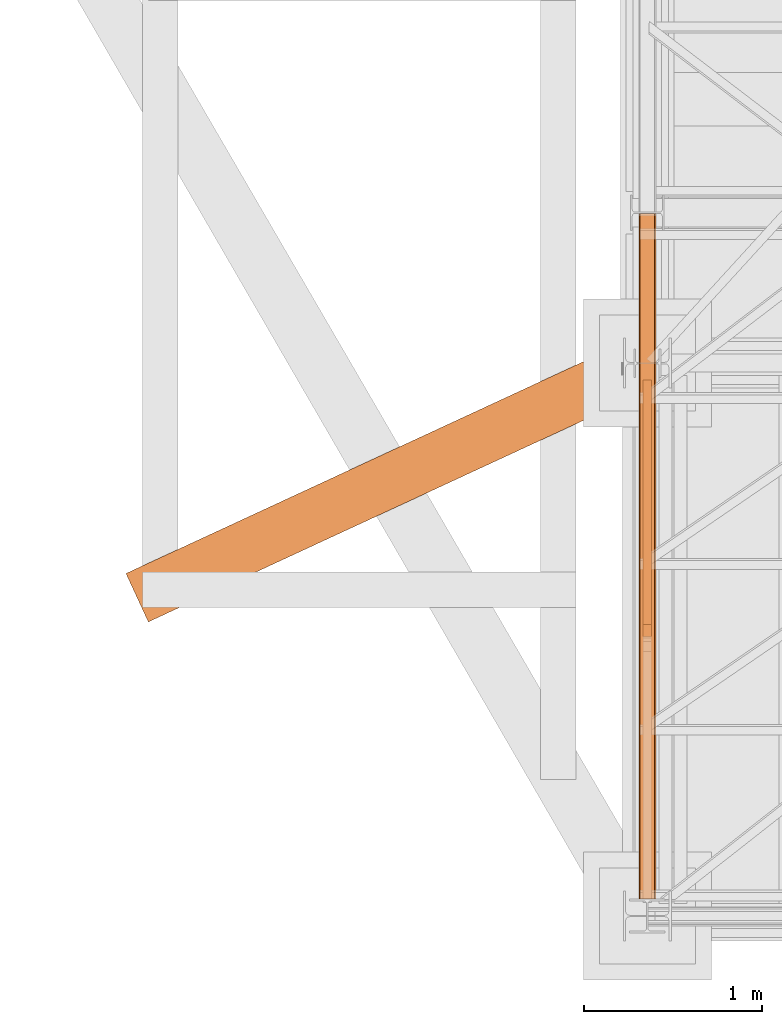
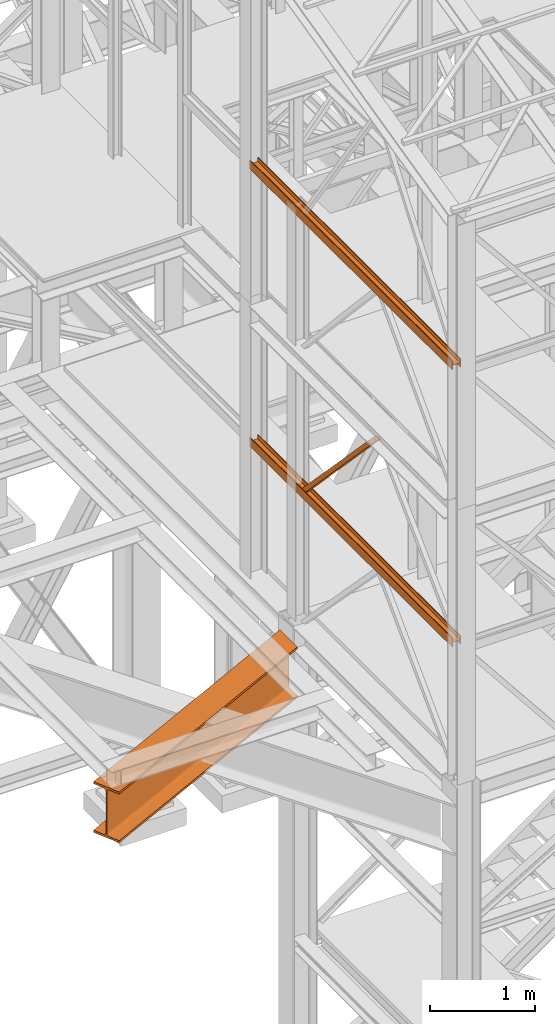
# One storey, part 11 of 208: 5 proxies.
"""IFC2X3 building model written with IfcOpenShell, lengths in millimetres."""

import ifcopenshell
import ifcopenshell.guid

model = None  # the IFC model being written
_history = None  # IfcOwnerHistory: only IFC2X3 demands one
_inside = {}  # id of a spatial element -> (the spatial element, [elements in it])
_under = {}  # id of a project, library or spatial element -> (it, [spatial elements below it])
_declared = {}  # id of a project -> (the project, [libraries it declares])
_typed = {}  # id of a type object -> (the type object, [elements of that type])
_made_of = {}  # id of a material, layer set ... -> (it, [elements and type objects made of it])


def new_model(schema):
    """Start an empty IFC model of exactly this schema.

    Asked for "IFC4X3", IfcOpenShell would pick the latest addendum, in which some entities
    have other attributes; the version numbers below select the first issue.
    IFC2X3 requires an IfcOwnerHistory on every rooted entity: one is made here for all.
    """
    global model, _history
    if schema == "IFC4X3":
        model = ifcopenshell.file(schema_version=(4, 3, 0, 0))
    else:
        model = ifcopenshell.file(schema=schema)
    _inside.clear()
    _under.clear()
    _declared.clear()
    _typed.clear()
    _made_of.clear()
    _history = None
    if model.schema == "IFC2X3":
        org = make("IfcOrganization", Name="unknown")
        user = make(
            "IfcPersonAndOrganization",
            ThePerson=make("IfcPerson", FamilyName="unknown"),
            TheOrganization=org,
        )
        app = make(
            "IfcApplication",
            ApplicationDeveloper=org,
            Version="unknown",
            ApplicationFullName="unknown",
            ApplicationIdentifier="unknown",
        )
        _history = make(
            "IfcOwnerHistory",
            OwningUser=user,
            OwningApplication=app,
            ChangeAction="ADDED",
            CreationDate=0,
        )
    return model


def make(cls, **values):
    """One entity of the class cls with the attributes given. An attribute that is None is left unset."""
    return model.create_entity(
        cls, **{name: value for name, value in values.items() if value is not None}
    )


def entity(cls, *values):
    """Any entity or typed value of the class cls, its attributes in the order of the schema. None: left unset."""
    e = model.create_entity(cls)
    for i, value in enumerate(values):
        if value is not None:
            e[i] = value
    return e


def rooted(cls, **values):
    """An entity with a GlobalId (a new one), such as an element, a storey or a relation."""
    return make(cls, GlobalId=ifcopenshell.guid.new(), OwnerHistory=_history, **values)


def si_unit(unit_type, name, prefix=None):
    """IfcSIUnit, for example si_unit("LENGTHUNIT", "METRE", prefix="MILLI")."""
    return make("IfcSIUnit", UnitType=unit_type, Prefix=prefix, Name=name)


def converted_unit(unit_type, name, factor, base, dimensions=None, offset=None):
    """IfcConversionBasedUnit, such as the inch: factor (a typed value) times the base unit."""
    return make(
        "IfcConversionBasedUnit"
        if offset is None
        else "IfcConversionBasedUnitWithOffset",
        ConversionOffset=offset,
        Dimensions=None
        if dimensions is None
        else entity("IfcDimensionalExponents", *dimensions),
        UnitType=unit_type,
        Name=name,
        ConversionFactor=make(
            "IfcMeasureWithUnit", ValueComponent=factor, UnitComponent=base
        ),
    )


def assignment(units):
    """IfcUnitAssignment: the units of a project."""
    return None if units is None else make("IfcUnitAssignment", Units=units)


def point(xyz):
    """IfcCartesianPoint."""
    return None if xyz is None else make("IfcCartesianPoint", Coordinates=xyz)


def direction(xyz):
    """IfcDirection."""
    return None if xyz is None else make("IfcDirection", DirectionRatios=xyz)


def frame(location, z_axis=None, x_axis=None):
    """IfcAxis2Placement3D, a coordinate frame: its origin and axes. An axis left out is left unset."""
    return make(
        "IfcAxis2Placement3D",
        Location=point(location),
        Axis=direction(z_axis),
        RefDirection=direction(x_axis),
    )


def origin():
    """The frame at (0, 0, 0) with its axes left unset."""
    return frame((0.0, 0.0, 0.0))


def origin_with_axes():
    """The frame at (0, 0, 0) with the z axis (0, 0, 1) and the x axis (1, 0, 0) written out."""
    return frame((0.0, 0.0, 0.0), z_axis=(0.0, 0.0, 1.0), x_axis=(1.0, 0.0, 0.0))


def place(relative_to, where):
    """IfcLocalPlacement: puts the frame where relative to a parent placement (None: the world)."""
    return make(
        "IfcLocalPlacement", PlacementRelTo=relative_to, RelativePlacement=where
    )


def context(
    kind, dimensions, precision=None, world=None, true_north=None, identifier=None
):
    """IfcGeometricRepresentationContext, for example the 3D "Model" context."""
    return make(
        "IfcGeometricRepresentationContext",
        ContextIdentifier=identifier,
        ContextType=kind,
        CoordinateSpaceDimension=dimensions,
        Precision=precision,
        WorldCoordinateSystem=world,
        TrueNorth=true_north,
    )


def subcontext(parent, identifier, kind, view, scale=None):
    """IfcGeometricRepresentationSubContext, for example "Body" below "Model"."""
    return make(
        "IfcGeometricRepresentationSubContext",
        ContextIdentifier=identifier,
        ContextType=kind,
        ParentContext=parent,
        TargetScale=scale,
        TargetView=view,
    )


def project(units=None, contexts=None):
    """IfcProject with its units and contexts."""
    return rooted(
        "IfcProject",
        Name="project",
        RepresentationContexts=contexts,
        UnitsInContext=assignment(units),
    )


def spatial(cls, under=None, at=None, **own):
    """A site, building, storey or space (cls), placed at a placement, below another one or the project."""
    s = rooted(cls, ObjectPlacement=at, **own)
    if under is not None:
        _under.setdefault(under.id(), (under, []))[1].append(s)
    return s


def faces_of(points, faces, orient=None, outer=None):
    """IfcFace entities. A face is a list of loops; a loop is a list of indices into points, from 0.

    orient and outer hold one flag for each loop. By default every Orientation is true, the
    first loop of a face is its IfcFaceOuterBound and the others are IfcFaceBound.
    """
    made = []
    for i, loops in enumerate(faces):
        bounds = []
        for j, loop in enumerate(loops):
            is_outer = j == 0 if outer is None else outer[i][j]
            bounds.append(
                make(
                    "IfcFaceOuterBound" if is_outer else "IfcFaceBound",
                    Bound=make("IfcPolyLoop", Polygon=[points[k] for k in loop]),
                    Orientation=True if orient is None else orient[i][j],
                )
            )
        made.append(make("IfcFace", Bounds=bounds))
    return made


def faceted_brep(points, faces, orient=None, outer=None, voids=None):
    """IfcFacetedBrep: a solid bounded by flat faces; with voids (closed shells), ...WithVoids."""
    shared = [point(p) for p in points]
    hull = make("IfcClosedShell", CfsFaces=faces_of(shared, faces, orient, outer))
    if voids is None:
        return make("IfcFacetedBrep", Outer=hull)
    return make(
        "IfcFacetedBrepWithVoids",
        Outer=hull,
        Voids=[
            make(cls, CfsFaces=faces_of(shared, fs, o, b)) for cls, fs, o, b in voids
        ],
    )


def shape(context_of_items, identifier, shape_type, items):
    """IfcShapeRepresentation: the items that make up one representation, for example the "Body"."""
    return make(
        "IfcShapeRepresentation",
        ContextOfItems=context_of_items,
        RepresentationIdentifier=identifier,
        RepresentationType=shape_type,
        Items=items,
    )


def made_of(thing, what):
    """Note that an element or type object is made of a material, layer set ...; save() writes the relation."""
    if what is not None:
        _made_of.setdefault(what.id(), (what, []))[1].append(thing)
    return thing


def element(
    cls,
    number,
    at=None,
    inside=None,
    cuts=None,
    type_object=None,
    material=None,
    context=None,
    identifier="Body",
    shape_type=None,
    held_by="IfcProductDefinitionShape",
    body=None,
    shapes=None,
    **own,
):
    """One element of the class cls, such as IfcWall. Its Tag is "e" and its number.

    at: its placement. inside: the storey or other place that contains it. cuts: it is an
    opening in that element (IfcRelVoidsElement). A single representation is given by context,
    identifier, shape_type and body (its items); several are given by shapes. held_by: the class
    of the entity that holds the representations. save() writes the other relations.
    """
    e = rooted(cls, Tag="e%d" % number, ObjectPlacement=at, **own)
    if body is not None:
        shapes = [shape(context, identifier, shape_type, body)]
    if shapes is not None:
        e.Representation = make(held_by, Representations=shapes)
    if inside is not None:
        _inside.setdefault(inside.id(), (inside, []))[1].append(e)
    if cuts is not None:
        rooted(
            "IfcRelVoidsElement", RelatingBuildingElement=cuts, RelatedOpeningElement=e
        )
    if type_object is not None:
        _typed.setdefault(type_object.id(), (type_object, []))[1].append(e)
    return made_of(e, material)


def aggregate(whole, parts):
    """IfcRelAggregates: a whole, such as a stair, and the parts it consists of."""
    return rooted("IfcRelAggregates", RelatingObject=whole, RelatedObjects=parts)


def save(model, path):
    """Write the relations noted so far, then the file.

    IfcRelAggregates (storeys below a building ...), IfcRelContainedInSpatialStructure (elements
    in a storey), IfcRelDefinesByType, IfcRelAssociatesMaterial and IfcRelDeclares: one each for
    every whole, place, type object, material and project.
    """
    for whole, parts in _under.values():
        aggregate(whole, parts)
    for where, things in _inside.values():
        rooted(
            "IfcRelContainedInSpatialStructure",
            RelatedElements=things,
            RelatingStructure=where,
        )
    for kind, things in _typed.values():
        rooted("IfcRelDefinesByType", RelatedObjects=things, RelatingType=kind)
    for what, things in _made_of.values():
        rooted("IfcRelAssociatesMaterial", RelatedObjects=things, RelatingMaterial=what)
    for by, libraries in _declared.values():
        rooted("IfcRelDeclares", RelatingContext=by, RelatedDefinitions=libraries)
    model.write(path)


model = new_model("IFC2X3")

# Units and contexts
model_context = context("Model", 3, precision=1e-05, world=origin())
plan_context = context("Plan", 3, precision=1e-05, world=origin())
body_context = subcontext(model_context, "Body", "Model", "MODEL_VIEW")
ifc_project = project(units=[si_unit("LENGTHUNIT", "METRE", prefix="MILLI"), converted_unit("PLANEANGLEUNIT", "DEGREE", entity("IfcPlaneAngleMeasure", 0.0174532925199433), si_unit("PLANEANGLEUNIT", "RADIAN"), dimensions=[0, 0, 0, 0, 0, 0, 0]), si_unit("AREAUNIT", "SQUARE_METRE"), si_unit("VOLUMEUNIT", "CUBIC_METRE")], contexts=[model_context, plan_context])

# Building, storey
building_placement = place(None, origin())
building = spatial("IfcBuilding", under=ifc_project, at=building_placement, CompositionType="COMPLEX")
storey_placement = place(building_placement, origin_with_axes())
storey = spatial("IfcBuildingStorey", under=building, at=storey_placement, Name="Geschoss", CompositionType="ELEMENT")

# Proxies
proxy_1_placement = place(storey_placement, frame((1150.254968528655, -25077.57438405939, 9979.990000745052), z_axis=(0.0, 0.0, 1.0), x_axis=(1.0, 0.0, 0.0)))
element("IfcBuildingElementProxy", 1, at=proxy_1_placement, inside=storey, context=body_context, shape_type="Brep", body=[
    faceted_brep([(8.009999999999991, 3856.759993674456, 0.01000000000021828), (8.009999999999991, 3856.759993674456, 47.51000000000022), (88.00999999999999, 3856.759993674456, 47.51000000000022), (88.00999999999999, 3856.759993674456, 0.01000000000021828), (96.00999999999999, 3856.759993674456, 0.01000000000021828), (96.00999999999999, 3856.759993674456, 100.0100000000002), (88.00999999999999, 3856.759993674456, 100.0100000000002), (88.00999999999999, 3856.759993674456, 52.51000000000022), (8.009999999999991, 3856.759993674456, 52.51000000000022), (8.009999999999991, 3856.759993674456, 100.0100000000002), (0.009999999999990905, 3856.759993674456, 100.0100000000002), (0.009999999999990905, 3856.759993674456, 0.01000000000021828), (0.009999999999990905, 3856.759993674456, 0.01000000000021828), (0.009999999999990905, 0.01000000000203727, 0.01000000000021828), (8.009999999999991, 0.01000000000203727, 0.01000000000021828), (8.009999999999991, 3856.759993674456, 0.01000000000021828), (0.009999999999990905, 3856.759993674456, 100.0100000000002), (0.009999999999990905, 0.01000000000203727, 100.0100000000002), (0.009999999999990905, 0.01000000000203727, 0.01000000000021828), (0.009999999999990905, 3856.759993674456, 0.01000000000021828), (8.009999999999991, 3856.759993674456, 100.0100000000002), (8.009999999999991, 0.01000000000203727, 100.0100000000002), (0.009999999999990905, 0.01000000000203727, 100.0100000000002), (0.009999999999990905, 3856.759993674456, 100.0100000000002), (8.009999999999991, 3856.759993674456, 52.51000000000022), (8.009999999999991, 0.01000000000203727, 52.51000000000022), (8.009999999999991, 0.01000000000203727, 100.0100000000002), (8.009999999999991, 3856.759993674456, 100.0100000000002), (88.00999999999999, 3856.759993674456, 52.51000000000022), (88.00999999999999, 0.01000000000203727, 52.51000000000022), (8.009999999999991, 0.01000000000203727, 52.51000000000022), (8.009999999999991, 3856.759993674456, 52.51000000000022), (88.00999999999999, 3856.759993674456, 100.0100000000002), (88.00999999999999, 0.01000000000203727, 100.0100000000002), (88.00999999999999, 0.01000000000203727, 52.51000000000022), (88.00999999999999, 3856.759993674456, 52.51000000000022), (96.00999999999999, 3856.759993674456, 100.0100000000002), (96.00999999999999, 0.01000000000203727, 100.0100000000002), (88.00999999999999, 0.01000000000203727, 100.0100000000002), (88.00999999999999, 3856.759993674456, 100.0100000000002), (96.00999999999999, 3856.759993674456, 0.01000000000021828), (96.00999999999999, 0.01000000000203727, 0.01000000000021828), (96.00999999999999, 0.01000000000203727, 100.0100000000002), (96.00999999999999, 3856.759993674456, 100.0100000000002), (88.00999999999999, 3856.759993674456, 0.01000000000021828), (88.00999999999999, 0.01000000000203727, 0.01000000000021828), (96.00999999999999, 0.01000000000203727, 0.01000000000021828), (96.00999999999999, 3856.759993674456, 0.01000000000021828), (88.00999999999999, 3856.759993674456, 47.51000000000022), (88.00999999999999, 0.01000000000203727, 47.51000000000022), (88.00999999999999, 0.01000000000203727, 0.01000000000021828), (88.00999999999999, 3856.759993674456, 0.01000000000021828), (8.009999999999991, 3856.759993674456, 47.51000000000022), (8.009999999999991, 0.01000000000203727, 47.51000000000022), (88.00999999999999, 0.01000000000203727, 47.51000000000022), (88.00999999999999, 3856.759993674456, 47.51000000000022), (8.009999999999991, 3856.759993674456, 0.01000000000021828), (8.009999999999991, 0.01000000000203727, 0.01000000000021828), (8.009999999999991, 0.01000000000203727, 47.51000000000022), (8.009999999999991, 3856.759993674456, 47.51000000000022), (8.009999999999991, 0.01000000000203727, 0.01000000000021828), (0.009999999999990905, 0.01000000000203727, 0.01000000000021828), (0.009999999999990905, 0.01000000000203727, 100.0100000000002), (8.009999999999991, 0.01000000000203727, 100.0100000000002), (8.009999999999991, 0.01000000000203727, 52.51000000000022), (88.00999999999999, 0.01000000000203727, 52.51000000000022), (88.00999999999999, 0.01000000000203727, 100.0100000000002), (96.00999999999999, 0.01000000000203727, 100.0100000000002), (96.00999999999999, 0.01000000000203727, 0.01000000000021828), (88.00999999999999, 0.01000000000203727, 0.01000000000021828), (88.00999999999999, 0.01000000000203727, 47.51000000000022), (8.009999999999991, 0.01000000000203727, 47.51000000000022)], [[[0, 1, 2, 3, 4, 5, 6, 7, 8, 9, 10, 11]], [[12, 13, 14, 15]], [[16, 17, 18, 19]], [[20, 21, 22, 23]], [[24, 25, 26, 27]], [[28, 29, 30, 31]], [[32, 33, 34, 35]], [[36, 37, 38, 39]], [[40, 41, 42, 43]], [[44, 45, 46, 47]], [[48, 49, 50, 51]], [[52, 53, 54, 55]], [[56, 57, 58, 59]], [[60, 61, 62, 63, 64, 65, 66, 67, 68, 69, 70, 71]]], orient=[[False], [False], [False], [False], [False], [False], [False], [False], [False], [False], [False], [False], [False], [False]]),
])
proxy_2_placement = place(storey_placement, frame((1150.254968528655, -25077.57438405939, 9979.990000745052), z_axis=(0.0, 0.0, 1.0), x_axis=(1.0, 0.0, 0.0)))
element("IfcBuildingElementProxy", 2, at=proxy_2_placement, inside=storey, context=body_context, shape_type="Brep", body=[
    faceted_brep([(8.009999999999991, 3856.759993674456, 0.01000000000021828), (8.009999999999991, 3856.759993674456, 47.51000000000022), (88.00999999999999, 3856.759993674456, 47.51000000000022), (88.00999999999999, 3856.759993674456, 0.01000000000021828), (96.00999999999999, 3856.759993674456, 0.01000000000021828), (96.00999999999999, 3856.759993674456, 100.0100000000002), (88.00999999999999, 3856.759993674456, 100.0100000000002), (88.00999999999999, 3856.759993674456, 52.51000000000022), (8.009999999999991, 3856.759993674456, 52.51000000000022), (8.009999999999991, 3856.759993674456, 100.0100000000002), (0.009999999999990905, 3856.759993674456, 100.0100000000002), (0.009999999999990905, 3856.759993674456, 0.01000000000021828), (0.009999999999990905, 3856.759993674456, 0.01000000000021828), (0.009999999999990905, 0.01000000000203727, 0.01000000000021828), (8.009999999999991, 0.01000000000203727, 0.01000000000021828), (8.009999999999991, 3856.759993674456, 0.01000000000021828), (0.009999999999990905, 3856.759993674456, 100.0100000000002), (0.009999999999990905, 0.01000000000203727, 100.0100000000002), (0.009999999999990905, 0.01000000000203727, 0.01000000000021828), (0.009999999999990905, 3856.759993674456, 0.01000000000021828), (8.009999999999991, 3856.759993674456, 100.0100000000002), (8.009999999999991, 0.01000000000203727, 100.0100000000002), (0.009999999999990905, 0.01000000000203727, 100.0100000000002), (0.009999999999990905, 3856.759993674456, 100.0100000000002), (8.009999999999991, 3856.759993674456, 52.51000000000022), (8.009999999999991, 0.01000000000203727, 52.51000000000022), (8.009999999999991, 0.01000000000203727, 100.0100000000002), (8.009999999999991, 3856.759993674456, 100.0100000000002), (88.00999999999999, 3856.759993674456, 52.51000000000022), (88.00999999999999, 0.01000000000203727, 52.51000000000022), (8.009999999999991, 0.01000000000203727, 52.51000000000022), (8.009999999999991, 3856.759993674456, 52.51000000000022), (88.00999999999999, 3856.759993674456, 100.0100000000002), (88.00999999999999, 0.01000000000203727, 100.0100000000002), (88.00999999999999, 0.01000000000203727, 52.51000000000022), (88.00999999999999, 3856.759993674456, 52.51000000000022), (96.00999999999999, 3856.759993674456, 100.0100000000002), (96.00999999999999, 0.01000000000203727, 100.0100000000002), (88.00999999999999, 0.01000000000203727, 100.0100000000002), (88.00999999999999, 3856.759993674456, 100.0100000000002), (96.00999999999999, 3856.759993674456, 0.01000000000021828), (96.00999999999999, 0.01000000000203727, 0.01000000000021828), (96.00999999999999, 0.01000000000203727, 100.0100000000002), (96.00999999999999, 3856.759993674456, 100.0100000000002), (88.00999999999999, 3856.759993674456, 0.01000000000021828), (88.00999999999999, 0.01000000000203727, 0.01000000000021828), (96.00999999999999, 0.01000000000203727, 0.01000000000021828), (96.00999999999999, 3856.759993674456, 0.01000000000021828), (88.00999999999999, 3856.759993674456, 47.51000000000022), (88.00999999999999, 0.01000000000203727, 47.51000000000022), (88.00999999999999, 0.01000000000203727, 0.01000000000021828), (88.00999999999999, 3856.759993674456, 0.01000000000021828), (8.009999999999991, 3856.759993674456, 47.51000000000022), (8.009999999999991, 0.01000000000203727, 47.51000000000022), (88.00999999999999, 0.01000000000203727, 47.51000000000022), (88.00999999999999, 3856.759993674456, 47.51000000000022), (8.009999999999991, 3856.759993674456, 0.01000000000021828), (8.009999999999991, 0.01000000000203727, 0.01000000000021828), (8.009999999999991, 0.01000000000203727, 47.51000000000022), (8.009999999999991, 3856.759993674456, 47.51000000000022), (8.009999999999991, 0.01000000000203727, 0.01000000000021828), (0.009999999999990905, 0.01000000000203727, 0.01000000000021828), (0.009999999999990905, 0.01000000000203727, 100.0100000000002), (8.009999999999991, 0.01000000000203727, 100.0100000000002), (8.009999999999991, 0.01000000000203727, 52.51000000000022), (88.00999999999999, 0.01000000000203727, 52.51000000000022), (88.00999999999999, 0.01000000000203727, 100.0100000000002), (96.00999999999999, 0.01000000000203727, 100.0100000000002), (96.00999999999999, 0.01000000000203727, 0.01000000000021828), (88.00999999999999, 0.01000000000203727, 0.01000000000021828), (88.00999999999999, 0.01000000000203727, 47.51000000000022), (8.009999999999991, 0.01000000000203727, 47.51000000000022)], [[[0, 1, 2, 3, 4, 5, 6, 7, 8, 9, 10, 11]], [[12, 13, 14, 15]], [[16, 17, 18, 19]], [[20, 21, 22, 23]], [[24, 25, 26, 27]], [[28, 29, 30, 31]], [[32, 33, 34, 35]], [[36, 37, 38, 39]], [[40, 41, 42, 43]], [[44, 45, 46, 47]], [[48, 49, 50, 51]], [[52, 53, 54, 55]], [[56, 57, 58, 59]], [[60, 61, 62, 63, 64, 65, 66, 67, 68, 69, 70, 71]]], orient=[[False], [False], [False], [False], [False], [False], [False], [False], [False], [False], [False], [False], [False], [False]]),
])
proxy_3_placement = place(storey_placement, frame((1150.254968144219, -25077.57437538435, 6759.989999254943), z_axis=(0.0, 0.0, 1.0), x_axis=(1.0, 0.0, 0.0)))
element("IfcBuildingElementProxy", 3, at=proxy_3_placement, inside=storey, context=body_context, shape_type="Brep", body=[
    faceted_brep([(8.010000000000218, 0.00999999999839929, 0.01000000000021828), (0.01000000000021828, 0.00999999999839929, 0.01000000000021828), (0.01000000000021828, 0.00999999999839929, 100.0100000000002), (8.010000000000218, 0.00999999999839929, 100.0100000000002), (8.010000000000218, 0.00999999999839929, 52.51000000000022), (88.01000000000022, 0.00999999999839929, 52.51000000000022), (88.01000000000022, 0.00999999999839929, 100.0100000000002), (96.00999999999999, 0.00999999999839929, 100.0100000000002), (96.00999999999999, 0.00999999999839929, 0.01000000000021828), (88.01000000000022, 0.00999999999839929, 0.01000000000021828), (88.01000000000022, 0.00999999999839929, 47.51000000000022), (8.010000000000218, 0.00999999999839929, 47.51000000000022), (0.01000000000021828, 0.00999999999839929, 0.01000000000021828), (8.010000000000218, 0.00999999999839929, 0.01000000000021828), (8.010000000000673, 3856.759984999411, 0.01000000000021828), (0.01000000000067303, 3856.759984999411, 0.01000000000021828), (0.01000000000021828, 0.00999999999839929, 100.0100000000002), (0.01000000000021828, 0.00999999999839929, 0.01000000000021828), (0.01000000000067303, 3856.759984999411, 0.01000000000021828), (0.01000000000067303, 3856.759984999411, 100.0100000000002), (8.010000000000218, 0.00999999999839929, 100.0100000000002), (0.01000000000021828, 0.00999999999839929, 100.0100000000002), (0.01000000000067303, 3856.759984999411, 100.0100000000002), (8.010000000000673, 3856.759984999411, 100.0100000000002), (8.010000000000218, 0.00999999999839929, 52.51000000000022), (8.010000000000218, 0.00999999999839929, 100.0100000000002), (8.010000000000673, 3856.759984999411, 100.0100000000002), (8.010000000000673, 3856.759984999411, 52.51000000000022), (88.01000000000022, 0.00999999999839929, 52.51000000000022), (8.010000000000218, 0.00999999999839929, 52.51000000000022), (8.010000000000673, 3856.759984999411, 52.51000000000022), (88.01000000000067, 3856.759984999411, 52.51000000000022), (88.01000000000022, 0.00999999999839929, 100.0100000000002), (88.01000000000022, 0.00999999999839929, 52.51000000000022), (88.01000000000067, 3856.759984999411, 52.51000000000022), (88.01000000000067, 3856.759984999411, 100.0100000000002), (96.00999999999999, 0.00999999999839929, 100.0100000000002), (88.01000000000022, 0.00999999999839929, 100.0100000000002), (88.01000000000067, 3856.759984999411, 100.0100000000002), (96.01000000000045, 3856.759984999411, 100.0100000000002), (96.00999999999999, 0.00999999999839929, 0.01000000000021828), (96.00999999999999, 0.00999999999839929, 100.0100000000002), (96.01000000000045, 3856.759984999411, 100.0100000000002), (96.01000000000045, 3856.759984999411, 0.01000000000021828), (88.01000000000022, 0.00999999999839929, 0.01000000000021828), (96.00999999999999, 0.00999999999839929, 0.01000000000021828), (96.01000000000045, 3856.759984999411, 0.01000000000021828), (88.01000000000067, 3856.759984999411, 0.01000000000021828), (88.01000000000022, 0.00999999999839929, 47.51000000000022), (88.01000000000022, 0.00999999999839929, 0.01000000000021828), (88.01000000000067, 3856.759984999411, 0.01000000000021828), (88.01000000000067, 3856.759984999411, 47.51000000000022), (8.010000000000218, 0.00999999999839929, 47.51000000000022), (88.01000000000022, 0.00999999999839929, 47.51000000000022), (88.01000000000067, 3856.759984999411, 47.51000000000022), (8.010000000000673, 3856.759984999411, 47.51000000000022), (8.010000000000218, 0.00999999999839929, 0.01000000000021828), (8.010000000000218, 0.00999999999839929, 47.51000000000022), (8.010000000000673, 3856.759984999411, 47.51000000000022), (8.010000000000673, 3856.759984999411, 0.01000000000021828), (8.010000000000673, 3856.759984999411, 0.01000000000021828), (8.010000000000673, 3856.759984999411, 47.51000000000022), (88.01000000000067, 3856.759984999411, 47.51000000000022), (88.01000000000067, 3856.759984999411, 0.01000000000021828), (96.01000000000045, 3856.759984999411, 0.01000000000021828), (96.01000000000045, 3856.759984999411, 100.0100000000002), (88.01000000000067, 3856.759984999411, 100.0100000000002), (88.01000000000067, 3856.759984999411, 52.51000000000022), (8.010000000000673, 3856.759984999411, 52.51000000000022), (8.010000000000673, 3856.759984999411, 100.0100000000002), (0.01000000000067303, 3856.759984999411, 100.0100000000002), (0.01000000000067303, 3856.759984999411, 0.01000000000021828)], [[[0, 1, 2, 3, 4, 5, 6, 7, 8, 9, 10, 11]], [[12, 13, 14, 15]], [[16, 17, 18, 19]], [[20, 21, 22, 23]], [[24, 25, 26, 27]], [[28, 29, 30, 31]], [[32, 33, 34, 35]], [[36, 37, 38, 39]], [[40, 41, 42, 43]], [[44, 45, 46, 47]], [[48, 49, 50, 51]], [[52, 53, 54, 55]], [[56, 57, 58, 59]], [[60, 61, 62, 63, 64, 65, 66, 67, 68, 69, 70, 71]]], orient=[[False], [False], [False], [False], [False], [False], [False], [False], [False], [False], [False], [False], [False], [False]]),
])
proxy_4_placement = place(storey_placement, frame((1173.25497001878, -23599.68394796683, 6812.489999254941), z_axis=(0.0, 0.0, 1.0), x_axis=(1.0, 0.0, 0.0)))
element("IfcBuildingElementProxy", 4, at=proxy_4_placement, inside=storey, context=body_context, shape_type="Brep", body=[
    faceted_brep([(50.01000074505896, 1442.119560065505, 0.01000000000203727), (50.01000074505805, 65.88299731319057, 1442.509998658895), (0.009999999999990905, 65.88299731319057, 1442.509998658895), (0.0100000000009004, 1442.119560065505, 0.01000000000021828), (50.01000074505896, 1374.898569487355, 0.1025547097042363), (50.01000074505805, 0.00999999999839929, 1442.509998658895), (50.01000074505805, 65.88299731319057, 1442.509998658895), (50.01000074505896, 1442.119560065505, 0.01000000000203727), (50.01000074505896, 1382.119560065505, 0.01000000000203727), (0.0100000000009004, 1374.898569487355, 0.1025547097042363), (0.009999999999990905, 0.00999999999839929, 1442.509998658893), (50.01000074505805, 0.00999999999839929, 1442.509998658895), (50.01000074505896, 1374.898569487355, 0.1025547097042363), (0.0100000000009004, 1442.119560065505, 0.01000000000021828), (0.009999999999990905, 65.88299731319057, 1442.509998658895), (0.009999999999990905, 0.00999999999839929, 1442.509998658893), (0.0100000000009004, 1374.898569487355, 0.1025547097042363), (0.0100000000009004, 1382.119560065505, 0.01000000000203727), (0.0100000000009004, 1382.119560065505, 0.01000000000203727), (0.0100000000009004, 1374.898569487355, 0.1025547097042363), (50.01000074505896, 1374.898569487355, 0.1025547097042363), (50.01000074505896, 1382.119560065505, 0.01000000000203727), (0.0100000000009004, 1442.119560065505, 0.01000000000021828), (0.0100000000009004, 1382.119560065505, 0.01000000000203727), (50.01000074505896, 1382.119560065505, 0.01000000000203727), (50.01000074505896, 1442.119560065505, 0.01000000000203727), (50.01000074505805, 65.88299731319057, 1442.509998658895), (50.01000074505805, 0.00999999999839929, 1442.509998658895), (0.009999999999990905, 0.00999999999839929, 1442.509998658893), (0.009999999999990905, 65.88299731319057, 1442.509998658895)], [[[0, 1, 2, 3]], [[4, 5, 6, 7, 8]], [[9, 10, 11, 12]], [[13, 14, 15, 16, 17]], [[18, 19, 20, 21]], [[22, 23, 24, 25]], [[26, 27, 28, 29]]], orient=[[False], [False], [False], [False], [False], [False], [False]]),
])
proxy_5_placement = place(storey_placement, frame((-1733.862688303826, -23518.70018502876, 4504.990005364416), z_axis=(0.0, 0.0, 1.0), x_axis=(1.0, 0.0, 0.0)))
element("IfcBuildingElementProxy", 5, at=proxy_5_placement, inside=storey, context=body_context, shape_type="Brep", body=[
    faceted_brep([(125.6925178439192, 0.00999999999839929, 590.0100000000002), (2797.037501721418, 1237.063855984325, 590.0100000000002), (2797.037501721418, 1237.063855984325, 565.0100000000002), (125.6925178439192, 0.00999999999839929, 565.0100000000002), (125.6925178439192, 0.00999999999839929, 565.0100000000002), (2797.037501721418, 1237.063855984325, 565.0100000000002), (2797.037501721418, 1365.449058007289, 565.0100000000002), (76.88580674786272, 105.7936546662277, 565.0100000000002), (76.88580674786272, 105.7936546662277, 565.0100000000002), (2797.037501721418, 1365.449058007289, 565.0100000000002), (2797.037501721418, 1374.643676172054, 563.6884339422604), (73.39039555299996, 113.3696081048147, 563.6884339422595), (73.39039555299996, 113.3696081048147, 563.6884339422595), (2797.037501721418, 1374.643676172054, 563.6884339422604), (2797.037501721418, 1382.938290899678, 559.8534254634033), (70.23712821155232, 120.2039990323538, 559.8534254634023), (70.23712821155232, 120.2039990323538, 559.8534254634023), (2797.037501721418, 1382.938290899678, 559.8534254634033), (2797.037501721418, 1389.520925741126, 553.8801750658022), (67.73468437927613, 125.6277952323071, 553.8801750658022), (67.73468437927613, 125.6277952323071, 553.8801750658022), (2797.037501721418, 1389.520925741126, 553.8801750658022), (2797.037501721417, 1393.74717757219, 546.3534305458616), (66.1280393073589, 129.1100374002854, 546.3534305458616), (66.1280393073589, 129.1100374002854, 546.3534305458616), (2797.037501721417, 1393.74717757219, 546.3534305458616), (2797.037501721418, 1395.203568347377, 538.0100000000002), (65.57438014191166, 130.3100381511067, 538.0100000000002), (65.57438014191166, 130.3100381511067, 538.0100000000002), (2797.037501721418, 1395.203568347377, 538.0100000000002), (2797.037501721418, 1395.203568347377, 52.01000000000022), (65.57438014191166, 130.3100381511067, 52.01000000000022), (65.57438014191166, 130.3100381511067, 52.01000000000022), (2797.037501721418, 1395.203568347377, 52.01000000000022), (2797.037501721418, 1393.747177572186, 43.6665694541407), (66.1280393073589, 129.1100374002854, 43.66656945413979), (66.1280393073589, 129.1100374002854, 43.66656945413979), (2797.037501721418, 1393.747177572186, 43.6665694541407), (2797.037501721418, 1389.52092574113, 36.13982493420008), (67.73468437927977, 125.6277952323071, 36.13982493420008), (67.73468437927977, 125.6277952323071, 36.13982493420008), (2797.037501721418, 1389.52092574113, 36.13982493420008), (2797.037501721418, 1382.938290899678, 30.166574536599), (70.23712821155232, 120.2039990323538, 30.166574536599), (70.23712821155232, 120.2039990323538, 30.166574536599), (2797.037501721418, 1382.938290899678, 30.166574536599), (2797.037501721418, 1374.643676172054, 26.33156605774093), (73.39039555299814, 113.3696081048147, 26.33156605774093), (73.39039555299814, 113.3696081048147, 26.33156605774093), (2797.037501721418, 1374.643676172054, 26.33156605774093), (2797.037501721418, 1365.449058007289, 25.01000000000022), (76.88580674786454, 105.7936546662277, 25.01000000000022), (76.88580674786454, 105.7936546662277, 25.01000000000022), (2797.037501721418, 1365.449058007289, 25.01000000000022), (2797.037501721417, 1237.063855984321, 25.01000000000022), (125.6925178439192, 0.00999999999839929, 25.01000000000022), (125.6925178439192, 0.00999999999839929, 25.01000000000022), (2797.037501721417, 1237.063855984321, 25.01000000000022), (2797.037501721418, 1237.063855984321, 0.01000000000021828), (125.6925178439192, 0.00999999999839929, 0.01000000000021828), (125.6925178439192, 0.00999999999839929, 0.01000000000021828), (2797.037501721418, 1237.063855984321, 0.01000000000021828), (2797.037501721418, 1567.669526429734, 0.01000000000021828), (0.01000000000158252, 272.4142609430819, 0.01000000000021828), (0.01000000000158252, 272.4142609430819, 0.01000000000021828), (2797.037501721418, 1567.669526429734, 0.01000000000021828), (2797.037501721418, 1567.669526429734, 25.01000000000022), (0.01000000000158252, 272.4142609430819, 25.01000000000022), (0.01000000000158252, 272.4142609430819, 25.01000000000022), (2797.037501721418, 1567.669526429734, 25.01000000000022), (2797.037501721418, 1439.284324406766, 25.01000000000022), (48.81671109605622, 166.630606276849, 25.01000000000022), (48.81671109605622, 166.630606276849, 25.01000000000022), (2797.037501721418, 1439.284324406766, 25.01000000000022), (2797.037501721417, 1430.089706242005, 26.33156605774093), (52.31212229092262, 159.0546528382693, 26.33156605774093), (52.31212229092262, 159.0546528382693, 26.33156605774093), (2797.037501721417, 1430.089706242005, 26.33156605774093), (2797.037501721418, 1421.795091514385, 30.166574536599), (55.46538963237026, 152.2202619107302, 30.166574536599), (55.46538963237026, 152.2202619107302, 30.166574536599), (2797.037501721418, 1421.795091514385, 30.166574536599), (2797.037501721418, 1415.212456672925, 36.13982493420008), (57.96783346464281, 146.7964657107732, 36.13982493419917), (57.96783346464281, 146.7964657107732, 36.13982493419917), (2797.037501721418, 1415.212456672925, 36.13982493420008), (2797.037501721418, 1410.986204841873, 43.6665694541407), (59.57447853656004, 143.3142235427949, 43.66656945413979), (59.57447853656004, 143.3142235427949, 43.66656945413979), (2797.037501721418, 1410.986204841873, 43.6665694541407), (2797.037501721418, 1409.529814066678, 52.01000000000113), (60.12813770200546, 142.11422279197, 52.01000000000022), (60.12813770200546, 142.11422279197, 52.01000000000022), (2797.037501721418, 1409.529814066678, 52.01000000000113), (2797.037501721418, 1409.529814066678, 538.0100000000002), (60.1281377020091, 142.1142227919736, 538.0100000000002), (60.1281377020091, 142.1142227919736, 538.0100000000002), (2797.037501721418, 1409.529814066678, 538.0100000000002), (2797.037501721418, 1410.986204841869, 546.3534305458616), (59.57447853656186, 143.3142235427949, 546.3534305458616), (59.57447853656186, 143.3142235427949, 546.3534305458616), (2797.037501721418, 1410.986204841869, 546.3534305458616), (2797.037501721418, 1415.212456672925, 553.8801750658022), (57.96783346464099, 146.7964657107732, 553.8801750658022), (57.96783346464099, 146.7964657107732, 553.8801750658022), (2797.037501721418, 1415.212456672925, 553.8801750658022), (2797.037501721418, 1421.795091514385, 559.8534254634033), (55.46538963237026, 152.2202619107302, 559.8534254634023), (55.46538963237026, 152.2202619107302, 559.8534254634023), (2797.037501721418, 1421.795091514385, 559.8534254634033), (2797.037501721418, 1430.089706242005, 563.6884339422604), (52.31212229092262, 159.0546528382693, 563.6884339422595), (52.31212229092262, 159.0546528382693, 563.6884339422595), (2797.037501721418, 1430.089706242005, 563.6884339422604), (2797.037501721418, 1439.284324406766, 565.0100000000002), (48.81671109605622, 166.630606276849, 565.0100000000002), (48.81671109605622, 166.630606276849, 565.0100000000002), (2797.037501721418, 1439.284324406766, 565.0100000000002), (2797.037501721418, 1567.669526429734, 565.010000000002), (0.009999999999763531, 272.4142609430819, 565.0100000000002), (0.009999999999763531, 272.4142609430819, 565.0100000000002), (2797.037501721418, 1567.669526429734, 565.010000000002), (2797.037501721418, 1567.669526429738, 590.0100000000002), (0.0100000000052205, 272.4142609430819, 590.0100000000002), (0.0100000000052205, 272.4142609430819, 590.0100000000002), (2797.037501721418, 1567.669526429738, 590.0100000000002), (2797.037501721418, 1237.063855984325, 590.0100000000002), (125.6925178439192, 0.00999999999839929, 590.0100000000002), (125.6925178439192, 0.00999999999839929, 565.0100000000002), (76.88580674786272, 105.7936546662277, 565.0100000000002), (73.39039555299996, 113.3696081048147, 563.6884339422595), (70.23712821155232, 120.2039990323538, 559.8534254634023), (67.73468437927613, 125.6277952323071, 553.8801750658022), (66.1280393073589, 129.1100374002854, 546.3534305458616), (65.57438014191166, 130.3100381511067, 538.0100000000002), (65.57438014191166, 130.3100381511067, 52.01000000000022), (66.1280393073589, 129.1100374002854, 43.66656945413979), (67.73468437927977, 125.6277952323071, 36.13982493420008), (70.23712821155232, 120.2039990323538, 30.166574536599), (73.39039555299814, 113.3696081048147, 26.33156605774093), (76.88580674786454, 105.7936546662277, 25.01000000000022), (125.6925178439192, 0.00999999999839929, 25.01000000000022), (125.6925178439192, 0.00999999999839929, 0.01000000000021828), (0.01000000000158252, 272.4142609430819, 0.01000000000021828), (0.01000000000158252, 272.4142609430819, 25.01000000000022), (48.81671109605622, 166.630606276849, 25.01000000000022), (52.31212229092262, 159.0546528382693, 26.33156605774093), (55.46538963237026, 152.2202619107302, 30.166574536599), (57.96783346464281, 146.7964657107732, 36.13982493419917), (59.57447853656004, 143.3142235427949, 43.66656945413979), (60.12813770200546, 142.11422279197, 52.01000000000022), (60.1281377020091, 142.1142227919736, 538.0100000000002), (59.57447853656186, 143.3142235427949, 546.3534305458616), (57.96783346464099, 146.7964657107732, 553.8801750658022), (55.46538963237026, 152.2202619107302, 559.8534254634023), (52.31212229092262, 159.0546528382693, 563.6884339422595), (48.81671109605622, 166.630606276849, 565.0100000000002), (0.009999999999763531, 272.4142609430819, 565.0100000000002), (0.0100000000052205, 272.4142609430819, 590.0100000000002), (125.6925178439192, 0.00999999999839929, 590.0100000000002), (2797.037501721418, 1237.063855984325, 565.0100000000002), (2797.037501721418, 1237.063855984325, 590.0100000000002), (2797.037501721418, 1567.669526429738, 590.0100000000002), (2797.037501721418, 1567.669526429734, 565.010000000002), (2797.037501721418, 1439.284324406766, 565.0100000000002), (2797.037501721418, 1430.089706242005, 563.6884339422604), (2797.037501721418, 1421.795091514385, 559.8534254634033), (2797.037501721418, 1415.212456672925, 553.8801750658022), (2797.037501721418, 1410.986204841869, 546.3534305458616), (2797.037501721418, 1409.529814066678, 538.0100000000002), (2797.037501721418, 1409.529814066678, 52.01000000000113), (2797.037501721418, 1410.986204841873, 43.6665694541407), (2797.037501721418, 1415.212456672925, 36.13982493420008), (2797.037501721418, 1421.795091514385, 30.166574536599), (2797.037501721417, 1430.089706242005, 26.33156605774093), (2797.037501721418, 1439.284324406766, 25.01000000000022), (2797.037501721418, 1567.669526429734, 25.01000000000022), (2797.037501721418, 1567.669526429734, 0.01000000000021828), (2797.037501721418, 1237.063855984321, 0.01000000000021828), (2797.037501721417, 1237.063855984321, 25.01000000000022), (2797.037501721418, 1365.449058007289, 25.01000000000022), (2797.037501721418, 1374.643676172054, 26.33156605774093), (2797.037501721418, 1382.938290899678, 30.166574536599), (2797.037501721418, 1389.52092574113, 36.13982493420008), (2797.037501721418, 1393.747177572186, 43.6665694541407), (2797.037501721418, 1395.203568347377, 52.01000000000022), (2797.037501721418, 1395.203568347377, 538.0100000000002), (2797.037501721417, 1393.74717757219, 546.3534305458616), (2797.037501721418, 1389.520925741126, 553.8801750658022), (2797.037501721418, 1382.938290899678, 559.8534254634033), (2797.037501721418, 1374.643676172054, 563.6884339422604), (2797.037501721418, 1365.449058007289, 565.0100000000002)], [[[0, 1, 2, 3]], [[4, 5, 6, 7]], [[8, 9, 10, 11]], [[12, 13, 14, 15]], [[16, 17, 18, 19]], [[20, 21, 22, 23]], [[24, 25, 26, 27]], [[28, 29, 30, 31]], [[32, 33, 34, 35]], [[36, 37, 38, 39]], [[40, 41, 42, 43]], [[44, 45, 46, 47]], [[48, 49, 50, 51]], [[52, 53, 54, 55]], [[56, 57, 58, 59]], [[60, 61, 62, 63]], [[64, 65, 66, 67]], [[68, 69, 70, 71]], [[72, 73, 74, 75]], [[76, 77, 78, 79]], [[80, 81, 82, 83]], [[84, 85, 86, 87]], [[88, 89, 90, 91]], [[92, 93, 94, 95]], [[96, 97, 98, 99]], [[100, 101, 102, 103]], [[104, 105, 106, 107]], [[108, 109, 110, 111]], [[112, 113, 114, 115]], [[116, 117, 118, 119]], [[120, 121, 122, 123]], [[124, 125, 126, 127]], [[128, 129, 130, 131, 132, 133, 134, 135, 136, 137, 138, 139, 140, 141, 142, 143, 144, 145, 146, 147, 148, 149, 150, 151, 152, 153, 154, 155, 156, 157, 158, 159]], [[160, 161, 162, 163, 164, 165, 166, 167, 168, 169, 170, 171, 172, 173, 174, 175, 176, 177, 178, 179, 180, 181, 182, 183, 184, 185, 186, 187, 188, 189, 190, 191]]], orient=[[False], [False], [False], [False], [False], [False], [False], [False], [False], [False], [False], [False], [False], [False], [False], [False], [False], [False], [False], [False], [False], [False], [False], [False], [False], [False], [False], [False], [False], [False], [False], [False], [False], [False]]),
])

save(model, "model.ifc")
